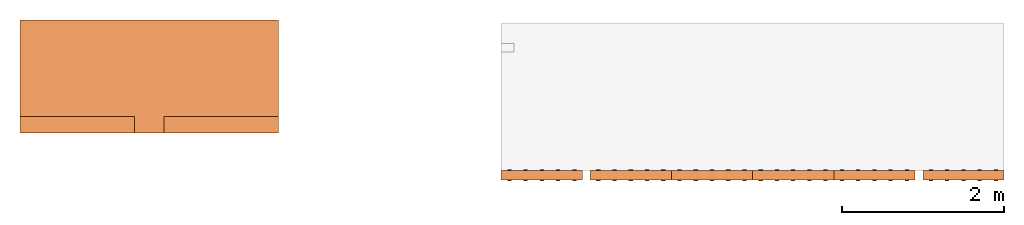
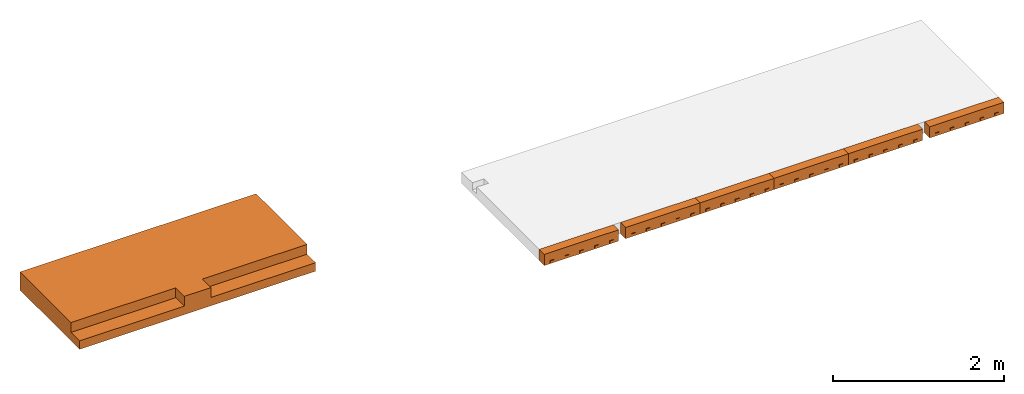
# Not in any storey, part 2 of 2: 7 proxies.
"""IFC2X3 building model written with IfcOpenShell, lengths in metres."""

from ifc_helpers import new_model, entity, si_unit, converted_unit, derived_unit, frame, origin, place, context, subcontext, project, spatial, faceted_brep, material, element, save


model = new_model("IFC2X3")

# Units and contexts
model_context = context("Model", 3, precision=1e-05, world=origin())
body_context = subcontext(model_context, "Body", "Model", "MODEL_VIEW")
ifc_project = project(units=[si_unit("LENGTHUNIT", "METRE"), si_unit("AREAUNIT", "SQUARE_METRE"), si_unit("VOLUMEUNIT", "CUBIC_METRE"), si_unit("MASSUNIT", "GRAM", prefix="KILO"), converted_unit("PLANEANGLEUNIT", "DEGREE", entity("IfcPlaneAngleMeasure", 0.0174532925199433), si_unit("PLANEANGLEUNIT", "RADIAN"), dimensions=[0, 0, 0, 0, 0, 0, 0]), derived_unit("THERMALTRANSMITTANCEUNIT", [(si_unit("POWERUNIT", "WATT"), 1), (si_unit("THERMODYNAMICTEMPERATUREUNIT", "KELVIN"), -1), (si_unit("LENGTHUNIT", "METRE"), -2)]), derived_unit("VOLUMETRICFLOWRATEUNIT", [(si_unit("LENGTHUNIT", "METRE"), 3), (converted_unit("TIMEUNIT", "hour", entity("IfcTimeMeasure", 3600.0), si_unit("TIMEUNIT", "SECOND"), dimensions=[0, 0, 1, 0, 0, 0, 0]), -1), (si_unit("LENGTHUNIT", "METRE"), -1)])], contexts=[model_context])

# Building
building_placement = place(None, origin())
building = spatial("IfcBuilding", under=ifc_project, at=building_placement, CompositionType="ELEMENT")

# Proxies
ifc_material = material()
proxy_1_placement = place(building_placement, frame((39.4091854451497, 4.88585415554066, 7.24)))
element("IfcBuildingElementProxy", 1, at=proxy_1_placement, inside=building, material=ifc_material, context=body_context, shape_type="Brep", body=[
    faceted_brep([(3.17999994515257, 1.39, 0.0), (0.0, 1.39, 0.0), (0.0, 0.0, 0.0), (3.17999994515257, 0.0, 0.0), (0.0, 1.39, 0.26), (3.17999994515257, 1.39, 0.26), (3.17999994515257, 0.200000000000004, 0.26), (1.76999994515256, 0.200000000000004, 0.26), (1.76999994515256, 0.0, 0.26), (1.41, 0.0, 0.26), (1.41, 0.200000000000004, 0.26), (0.0, 0.200000000000004, 0.26), (0.0, 0.200000000000004, 0.12), (0.0, 0.0, 0.12), (1.41, 0.0, 0.12), (1.76999994515256, 0.0, 0.12), (3.17999994515257, 0.0, 0.12), (3.17999994515256, 0.200000000000004, 0.12), (1.76999994515256, 0.200000000000004, 0.12), (1.41, 0.200000000000004, 0.12)], [[[0, 1, 2, 3]], [[4, 5, 6, 7, 8, 9, 10, 11]], [[1, 0, 5, 4]], [[2, 1, 4, 11, 12, 13]], [[3, 2, 13, 14, 9, 8, 15, 16]], [[0, 3, 16, 17, 6, 5]], [[18, 17, 16, 15]], [[7, 6, 17, 18]], [[8, 7, 18, 15]], [[12, 19, 14, 13]], [[11, 10, 19, 12]], [[10, 9, 14, 19]]], orient=[[False], [False], [False], [False], [False], [False], [False], [False], [False], [False], [False], [False]]),
])
proxy_2_placement = place(building_placement, frame((45.3333417641677, 4.29444485852216, 6.71)))
element("IfcBuildingElementProxy", 2, at=proxy_2_placement, inside=building, context=body_context, shape_type="Brep", body=[
    faceted_brep([(0.0, 0.01, 0.0), (1.0, 0.01, 0.0), (1.0, 0.13, 0.0), (0.0, 0.13, 0.0), (1.0, 0.01, 0.16), (0.0, 0.01, 0.16), (0.0, 0.13, 0.16), (1.0, 0.13, 0.16)], [[[0, 1, 2, 3]], [[4, 5, 6, 7]], [[1, 0, 5, 4]], [[2, 1, 4, 7]], [[3, 2, 7, 6]], [[0, 3, 6, 5]]], orient=[[False], [False], [False], [False], [False], [False]]),
    faceted_brep([(0.925, 0.01, 0.0475), (0.925, 0.0, 0.0475), (0.875, 0.0, 0.0475), (0.875, 0.01, 0.0475), (0.925, 0.0, 0.0175), (0.925, 0.01, 0.0175), (0.875, 0.01, 0.0175), (0.875, 0.0, 0.0175)], [[[0, 1, 2, 3]], [[4, 5, 6, 7]], [[1, 0, 5, 4]], [[2, 1, 4, 7]], [[3, 2, 7, 6]], [[0, 3, 6, 5]]], orient=[[False], [False], [False], [False], [False], [False]]),
    faceted_brep([(0.925, 0.14, 0.0475), (0.925, 0.13, 0.0475), (0.875, 0.13, 0.0475), (0.875, 0.14, 0.0475), (0.925, 0.13, 0.0175), (0.925, 0.14, 0.0175), (0.875, 0.14, 0.0175), (0.875, 0.13, 0.0175)], [[[0, 1, 2, 3]], [[4, 5, 6, 7]], [[1, 0, 5, 4]], [[2, 1, 4, 7]], [[3, 2, 7, 6]], [[0, 3, 6, 5]]], orient=[[False], [False], [False], [False], [False], [False]]),
    faceted_brep([(0.725, 0.01, 0.0475), (0.725, 0.0, 0.0475), (0.675, 0.0, 0.0475), (0.675, 0.01, 0.0475), (0.725, 0.0, 0.0175), (0.725, 0.01, 0.0175), (0.675, 0.01, 0.0175), (0.675, 0.0, 0.0175)], [[[0, 1, 2, 3]], [[4, 5, 6, 7]], [[1, 0, 5, 4]], [[2, 1, 4, 7]], [[3, 2, 7, 6]], [[0, 3, 6, 5]]], orient=[[False], [False], [False], [False], [False], [False]]),
    faceted_brep([(0.725, 0.14, 0.0475), (0.725, 0.13, 0.0475), (0.675, 0.13, 0.0475), (0.675, 0.14, 0.0475), (0.725, 0.13, 0.0175), (0.725, 0.14, 0.0175), (0.675, 0.14, 0.0175), (0.675, 0.13, 0.0175)], [[[0, 1, 2, 3]], [[4, 5, 6, 7]], [[1, 0, 5, 4]], [[2, 1, 4, 7]], [[3, 2, 7, 6]], [[0, 3, 6, 5]]], orient=[[False], [False], [False], [False], [False], [False]]),
    faceted_brep([(0.125, 0.01, 0.0475), (0.125, 0.0, 0.0475), (0.075, 0.0, 0.0475), (0.075, 0.01, 0.0475), (0.125, 0.0, 0.0175), (0.125, 0.01, 0.0175), (0.075, 0.01, 0.0175), (0.075, 0.0, 0.0175)], [[[0, 1, 2, 3]], [[4, 5, 6, 7]], [[1, 0, 5, 4]], [[2, 1, 4, 7]], [[3, 2, 7, 6]], [[0, 3, 6, 5]]], orient=[[False], [False], [False], [False], [False], [False]]),
    faceted_brep([(0.125, 0.14, 0.0475), (0.125, 0.13, 0.0475), (0.075, 0.13, 0.0475), (0.075, 0.14, 0.0475), (0.125, 0.13, 0.0175), (0.125, 0.14, 0.0175), (0.075, 0.14, 0.0175), (0.075, 0.13, 0.0175)], [[[0, 1, 2, 3]], [[4, 5, 6, 7]], [[1, 0, 5, 4]], [[2, 1, 4, 7]], [[3, 2, 7, 6]], [[0, 3, 6, 5]]], orient=[[False], [False], [False], [False], [False], [False]]),
    faceted_brep([(0.325, 0.01, 0.0475), (0.325, 0.0, 0.0475), (0.275, 0.0, 0.0475), (0.275, 0.01, 0.0475), (0.325, 0.0, 0.0175), (0.325, 0.01, 0.0175), (0.275, 0.01, 0.0175), (0.275, 0.0, 0.0175)], [[[0, 1, 2, 3]], [[4, 5, 6, 7]], [[1, 0, 5, 4]], [[2, 1, 4, 7]], [[3, 2, 7, 6]], [[0, 3, 6, 5]]], orient=[[False], [False], [False], [False], [False], [False]]),
    faceted_brep([(0.325, 0.14, 0.0475), (0.325, 0.13, 0.0475), (0.275, 0.13, 0.0475), (0.275, 0.14, 0.0475), (0.325, 0.13, 0.0175), (0.325, 0.14, 0.0175), (0.275, 0.14, 0.0175), (0.275, 0.13, 0.0175)], [[[0, 1, 2, 3]], [[4, 5, 6, 7]], [[1, 0, 5, 4]], [[2, 1, 4, 7]], [[3, 2, 7, 6]], [[0, 3, 6, 5]]], orient=[[False], [False], [False], [False], [False], [False]]),
    faceted_brep([(0.525, 0.01, 0.0475), (0.525, 0.0, 0.0475), (0.475, 0.0, 0.0475), (0.475, 0.01, 0.0475), (0.525, 0.0, 0.0175), (0.525, 0.01, 0.0175), (0.475, 0.01, 0.0175), (0.475, 0.0, 0.0175)], [[[0, 1, 2, 3]], [[4, 5, 6, 7]], [[1, 0, 5, 4]], [[2, 1, 4, 7]], [[3, 2, 7, 6]], [[0, 3, 6, 5]]], orient=[[False], [False], [False], [False], [False], [False]]),
    faceted_brep([(0.525, 0.14, 0.0475), (0.525, 0.13, 0.0475), (0.475, 0.13, 0.0475), (0.475, 0.14, 0.0475), (0.525, 0.13, 0.0175), (0.525, 0.14, 0.0175), (0.475, 0.14, 0.0175), (0.475, 0.13, 0.0175)], [[[0, 1, 2, 3]], [[4, 5, 6, 7]], [[1, 0, 5, 4]], [[2, 1, 4, 7]], [[3, 2, 7, 6]], [[0, 3, 6, 5]]], orient=[[False], [False], [False], [False], [False], [False]]),
])
proxy_3_placement = place(building_placement, frame((50.5233417641677, 4.29444485852216, 6.71)))
element("IfcBuildingElementProxy", 3, at=proxy_3_placement, inside=building, context=body_context, shape_type="Brep", body=[
    faceted_brep([(0.0, 0.01, 0.0), (1.0, 0.01, 0.0), (1.0, 0.13, 0.0), (0.0, 0.13, 0.0), (1.0, 0.01, 0.16), (0.0, 0.01, 0.16), (0.0, 0.13, 0.16), (1.0, 0.13, 0.16)], [[[0, 1, 2, 3]], [[4, 5, 6, 7]], [[1, 0, 5, 4]], [[2, 1, 4, 7]], [[3, 2, 7, 6]], [[0, 3, 6, 5]]], orient=[[False], [False], [False], [False], [False], [False]]),
    faceted_brep([(0.925, 0.01, 0.0475), (0.925, 0.0, 0.0475), (0.875, 0.0, 0.0475), (0.875, 0.01, 0.0475), (0.925, 0.0, 0.0175), (0.925, 0.01, 0.0175), (0.875, 0.01, 0.0175), (0.875, 0.0, 0.0175)], [[[0, 1, 2, 3]], [[4, 5, 6, 7]], [[1, 0, 5, 4]], [[2, 1, 4, 7]], [[3, 2, 7, 6]], [[0, 3, 6, 5]]], orient=[[False], [False], [False], [False], [False], [False]]),
    faceted_brep([(0.925, 0.14, 0.0475), (0.925, 0.13, 0.0475), (0.875, 0.13, 0.0475), (0.875, 0.14, 0.0475), (0.925, 0.13, 0.0175), (0.925, 0.14, 0.0175), (0.875, 0.14, 0.0175), (0.875, 0.13, 0.0175)], [[[0, 1, 2, 3]], [[4, 5, 6, 7]], [[1, 0, 5, 4]], [[2, 1, 4, 7]], [[3, 2, 7, 6]], [[0, 3, 6, 5]]], orient=[[False], [False], [False], [False], [False], [False]]),
    faceted_brep([(0.725, 0.01, 0.0475), (0.725, 0.0, 0.0475), (0.675, 0.0, 0.0475), (0.675, 0.01, 0.0475), (0.725, 0.0, 0.0175), (0.725, 0.01, 0.0175), (0.675, 0.01, 0.0175), (0.675, 0.0, 0.0175)], [[[0, 1, 2, 3]], [[4, 5, 6, 7]], [[1, 0, 5, 4]], [[2, 1, 4, 7]], [[3, 2, 7, 6]], [[0, 3, 6, 5]]], orient=[[False], [False], [False], [False], [False], [False]]),
    faceted_brep([(0.725, 0.14, 0.0475), (0.725, 0.13, 0.0475), (0.675, 0.13, 0.0475), (0.675, 0.14, 0.0475), (0.725, 0.13, 0.0175), (0.725, 0.14, 0.0175), (0.675, 0.14, 0.0175), (0.675, 0.13, 0.0175)], [[[0, 1, 2, 3]], [[4, 5, 6, 7]], [[1, 0, 5, 4]], [[2, 1, 4, 7]], [[3, 2, 7, 6]], [[0, 3, 6, 5]]], orient=[[False], [False], [False], [False], [False], [False]]),
    faceted_brep([(0.125, 0.01, 0.0475), (0.125, 0.0, 0.0475), (0.075, 0.0, 0.0475), (0.075, 0.01, 0.0475), (0.125, 0.0, 0.0175), (0.125, 0.01, 0.0175), (0.075, 0.01, 0.0175), (0.075, 0.0, 0.0175)], [[[0, 1, 2, 3]], [[4, 5, 6, 7]], [[1, 0, 5, 4]], [[2, 1, 4, 7]], [[3, 2, 7, 6]], [[0, 3, 6, 5]]], orient=[[False], [False], [False], [False], [False], [False]]),
    faceted_brep([(0.125, 0.14, 0.0475), (0.125, 0.13, 0.0475), (0.075, 0.13, 0.0475), (0.075, 0.14, 0.0475), (0.125, 0.13, 0.0175), (0.125, 0.14, 0.0175), (0.075, 0.14, 0.0175), (0.075, 0.13, 0.0175)], [[[0, 1, 2, 3]], [[4, 5, 6, 7]], [[1, 0, 5, 4]], [[2, 1, 4, 7]], [[3, 2, 7, 6]], [[0, 3, 6, 5]]], orient=[[False], [False], [False], [False], [False], [False]]),
    faceted_brep([(0.325, 0.01, 0.0475), (0.325, 0.0, 0.0475), (0.275, 0.0, 0.0475), (0.275, 0.01, 0.0475), (0.325, 0.0, 0.0175), (0.325, 0.01, 0.0175), (0.275, 0.01, 0.0175), (0.275, 0.0, 0.0175)], [[[0, 1, 2, 3]], [[4, 5, 6, 7]], [[1, 0, 5, 4]], [[2, 1, 4, 7]], [[3, 2, 7, 6]], [[0, 3, 6, 5]]], orient=[[False], [False], [False], [False], [False], [False]]),
    faceted_brep([(0.325, 0.14, 0.0475), (0.325, 0.13, 0.0475), (0.275, 0.13, 0.0475), (0.275, 0.14, 0.0475), (0.325, 0.13, 0.0175), (0.325, 0.14, 0.0175), (0.275, 0.14, 0.0175), (0.275, 0.13, 0.0175)], [[[0, 1, 2, 3]], [[4, 5, 6, 7]], [[1, 0, 5, 4]], [[2, 1, 4, 7]], [[3, 2, 7, 6]], [[0, 3, 6, 5]]], orient=[[False], [False], [False], [False], [False], [False]]),
    faceted_brep([(0.525, 0.01, 0.0475), (0.525, 0.0, 0.0475), (0.475, 0.0, 0.0475), (0.475, 0.01, 0.0475), (0.525, 0.0, 0.0175), (0.525, 0.01, 0.0175), (0.475, 0.01, 0.0175), (0.475, 0.0, 0.0175)], [[[0, 1, 2, 3]], [[4, 5, 6, 7]], [[1, 0, 5, 4]], [[2, 1, 4, 7]], [[3, 2, 7, 6]], [[0, 3, 6, 5]]], orient=[[False], [False], [False], [False], [False], [False]]),
    faceted_brep([(0.525, 0.14, 0.0475), (0.525, 0.13, 0.0475), (0.475, 0.13, 0.0475), (0.475, 0.14, 0.0475), (0.525, 0.13, 0.0175), (0.525, 0.14, 0.0175), (0.475, 0.14, 0.0175), (0.475, 0.13, 0.0175)], [[[0, 1, 2, 3]], [[4, 5, 6, 7]], [[1, 0, 5, 4]], [[2, 1, 4, 7]], [[3, 2, 7, 6]], [[0, 3, 6, 5]]], orient=[[False], [False], [False], [False], [False], [False]]),
])
proxy_4_placement = place(building_placement, frame((49.4283417641678, 4.29444487685715, 6.71)))
element("IfcBuildingElementProxy", 4, at=proxy_4_placement, inside=building, context=body_context, shape_type="Brep", body=[
    faceted_brep([(0.0, 0.01, 0.0), (1.0, 0.01, 0.0), (1.0, 0.13, 0.0), (0.0, 0.13, 0.0), (1.0, 0.01, 0.16), (0.0, 0.01, 0.16), (0.0, 0.13, 0.16), (1.0, 0.13, 0.16)], [[[0, 1, 2, 3]], [[4, 5, 6, 7]], [[1, 0, 5, 4]], [[2, 1, 4, 7]], [[3, 2, 7, 6]], [[0, 3, 6, 5]]], orient=[[False], [False], [False], [False], [False], [False]]),
    faceted_brep([(0.925, 0.01, 0.0475), (0.925, 0.0, 0.0475), (0.875, 0.0, 0.0475), (0.875, 0.01, 0.0475), (0.925, 0.0, 0.0175), (0.925, 0.01, 0.0175), (0.875, 0.01, 0.0175), (0.875, 0.0, 0.0175)], [[[0, 1, 2, 3]], [[4, 5, 6, 7]], [[1, 0, 5, 4]], [[2, 1, 4, 7]], [[3, 2, 7, 6]], [[0, 3, 6, 5]]], orient=[[False], [False], [False], [False], [False], [False]]),
    faceted_brep([(0.925, 0.14, 0.0475), (0.925, 0.13, 0.0475), (0.875, 0.13, 0.0475), (0.875, 0.14, 0.0475), (0.925, 0.13, 0.0175), (0.925, 0.14, 0.0175), (0.875, 0.14, 0.0175), (0.875, 0.13, 0.0175)], [[[0, 1, 2, 3]], [[4, 5, 6, 7]], [[1, 0, 5, 4]], [[2, 1, 4, 7]], [[3, 2, 7, 6]], [[0, 3, 6, 5]]], orient=[[False], [False], [False], [False], [False], [False]]),
    faceted_brep([(0.725, 0.01, 0.0475), (0.725, 0.0, 0.0475), (0.675, 0.0, 0.0475), (0.675, 0.01, 0.0475), (0.725, 0.0, 0.0175), (0.725, 0.01, 0.0175), (0.675, 0.01, 0.0175), (0.675, 0.0, 0.0175)], [[[0, 1, 2, 3]], [[4, 5, 6, 7]], [[1, 0, 5, 4]], [[2, 1, 4, 7]], [[3, 2, 7, 6]], [[0, 3, 6, 5]]], orient=[[False], [False], [False], [False], [False], [False]]),
    faceted_brep([(0.725, 0.14, 0.0475), (0.725, 0.13, 0.0475), (0.675, 0.13, 0.0475), (0.675, 0.14, 0.0475), (0.725, 0.13, 0.0175), (0.725, 0.14, 0.0175), (0.675, 0.14, 0.0175), (0.675, 0.13, 0.0175)], [[[0, 1, 2, 3]], [[4, 5, 6, 7]], [[1, 0, 5, 4]], [[2, 1, 4, 7]], [[3, 2, 7, 6]], [[0, 3, 6, 5]]], orient=[[False], [False], [False], [False], [False], [False]]),
    faceted_brep([(0.125, 0.01, 0.0475), (0.125, 0.0, 0.0475), (0.075, 0.0, 0.0475), (0.075, 0.01, 0.0475), (0.125, 0.0, 0.0175), (0.125, 0.01, 0.0175), (0.075, 0.01, 0.0175), (0.075, 0.0, 0.0175)], [[[0, 1, 2, 3]], [[4, 5, 6, 7]], [[1, 0, 5, 4]], [[2, 1, 4, 7]], [[3, 2, 7, 6]], [[0, 3, 6, 5]]], orient=[[False], [False], [False], [False], [False], [False]]),
    faceted_brep([(0.125, 0.14, 0.0475), (0.125, 0.13, 0.0475), (0.075, 0.13, 0.0475), (0.075, 0.14, 0.0475), (0.125, 0.13, 0.0175), (0.125, 0.14, 0.0175), (0.075, 0.14, 0.0175), (0.075, 0.13, 0.0175)], [[[0, 1, 2, 3]], [[4, 5, 6, 7]], [[1, 0, 5, 4]], [[2, 1, 4, 7]], [[3, 2, 7, 6]], [[0, 3, 6, 5]]], orient=[[False], [False], [False], [False], [False], [False]]),
    faceted_brep([(0.325, 0.01, 0.0475), (0.325, 0.0, 0.0475), (0.275, 0.0, 0.0475), (0.275, 0.01, 0.0475), (0.325, 0.0, 0.0175), (0.325, 0.01, 0.0175), (0.275, 0.01, 0.0175), (0.275, 0.0, 0.0175)], [[[0, 1, 2, 3]], [[4, 5, 6, 7]], [[1, 0, 5, 4]], [[2, 1, 4, 7]], [[3, 2, 7, 6]], [[0, 3, 6, 5]]], orient=[[False], [False], [False], [False], [False], [False]]),
    faceted_brep([(0.325, 0.14, 0.0475), (0.325, 0.13, 0.0475), (0.275, 0.13, 0.0475), (0.275, 0.14, 0.0475), (0.325, 0.13, 0.0175), (0.325, 0.14, 0.0175), (0.275, 0.14, 0.0175), (0.275, 0.13, 0.0175)], [[[0, 1, 2, 3]], [[4, 5, 6, 7]], [[1, 0, 5, 4]], [[2, 1, 4, 7]], [[3, 2, 7, 6]], [[0, 3, 6, 5]]], orient=[[False], [False], [False], [False], [False], [False]]),
    faceted_brep([(0.525, 0.01, 0.0475), (0.525, 0.0, 0.0475), (0.475, 0.0, 0.0475), (0.475, 0.01, 0.0475), (0.525, 0.0, 0.0175), (0.525, 0.01, 0.0175), (0.475, 0.01, 0.0175), (0.475, 0.0, 0.0175)], [[[0, 1, 2, 3]], [[4, 5, 6, 7]], [[1, 0, 5, 4]], [[2, 1, 4, 7]], [[3, 2, 7, 6]], [[0, 3, 6, 5]]], orient=[[False], [False], [False], [False], [False], [False]]),
    faceted_brep([(0.525, 0.14, 0.0475), (0.525, 0.13, 0.0475), (0.475, 0.13, 0.0475), (0.475, 0.14, 0.0475), (0.525, 0.13, 0.0175), (0.525, 0.14, 0.0175), (0.475, 0.14, 0.0175), (0.475, 0.13, 0.0175)], [[[0, 1, 2, 3]], [[4, 5, 6, 7]], [[1, 0, 5, 4]], [[2, 1, 4, 7]], [[3, 2, 7, 6]], [[0, 3, 6, 5]]], orient=[[False], [False], [False], [False], [False], [False]]),
])
proxy_5_placement = place(building_placement, frame((46.4283417641678, 4.29444487685715, 6.71)))
element("IfcBuildingElementProxy", 5, at=proxy_5_placement, inside=building, context=body_context, shape_type="Brep", body=[
    faceted_brep([(0.0, 0.01, 0.0), (1.0, 0.01, 0.0), (1.0, 0.13, 0.0), (0.0, 0.13, 0.0), (1.0, 0.01, 0.16), (0.0, 0.01, 0.16), (0.0, 0.13, 0.16), (1.0, 0.13, 0.16)], [[[0, 1, 2, 3]], [[4, 5, 6, 7]], [[1, 0, 5, 4]], [[2, 1, 4, 7]], [[3, 2, 7, 6]], [[0, 3, 6, 5]]], orient=[[False], [False], [False], [False], [False], [False]]),
    faceted_brep([(0.925, 0.01, 0.0475), (0.925, 0.0, 0.0475), (0.875, 0.0, 0.0475), (0.875, 0.01, 0.0475), (0.925, 0.0, 0.0175), (0.925, 0.01, 0.0175), (0.875, 0.01, 0.0175), (0.875, 0.0, 0.0175)], [[[0, 1, 2, 3]], [[4, 5, 6, 7]], [[1, 0, 5, 4]], [[2, 1, 4, 7]], [[3, 2, 7, 6]], [[0, 3, 6, 5]]], orient=[[False], [False], [False], [False], [False], [False]]),
    faceted_brep([(0.925, 0.14, 0.0475), (0.925, 0.13, 0.0475), (0.875, 0.13, 0.0475), (0.875, 0.14, 0.0475), (0.925, 0.13, 0.0175), (0.925, 0.14, 0.0175), (0.875, 0.14, 0.0175), (0.875, 0.13, 0.0175)], [[[0, 1, 2, 3]], [[4, 5, 6, 7]], [[1, 0, 5, 4]], [[2, 1, 4, 7]], [[3, 2, 7, 6]], [[0, 3, 6, 5]]], orient=[[False], [False], [False], [False], [False], [False]]),
    faceted_brep([(0.725, 0.01, 0.0475), (0.725, 0.0, 0.0475), (0.675, 0.0, 0.0475), (0.675, 0.01, 0.0475), (0.725, 0.0, 0.0175), (0.725, 0.01, 0.0175), (0.675, 0.01, 0.0175), (0.675, 0.0, 0.0175)], [[[0, 1, 2, 3]], [[4, 5, 6, 7]], [[1, 0, 5, 4]], [[2, 1, 4, 7]], [[3, 2, 7, 6]], [[0, 3, 6, 5]]], orient=[[False], [False], [False], [False], [False], [False]]),
    faceted_brep([(0.725, 0.14, 0.0475), (0.725, 0.13, 0.0475), (0.675, 0.13, 0.0475), (0.675, 0.14, 0.0475), (0.725, 0.13, 0.0175), (0.725, 0.14, 0.0175), (0.675, 0.14, 0.0175), (0.675, 0.13, 0.0175)], [[[0, 1, 2, 3]], [[4, 5, 6, 7]], [[1, 0, 5, 4]], [[2, 1, 4, 7]], [[3, 2, 7, 6]], [[0, 3, 6, 5]]], orient=[[False], [False], [False], [False], [False], [False]]),
    faceted_brep([(0.125, 0.01, 0.0475), (0.125, 0.0, 0.0475), (0.075, 0.0, 0.0475), (0.075, 0.01, 0.0475), (0.125, 0.0, 0.0175), (0.125, 0.01, 0.0175), (0.075, 0.01, 0.0175), (0.075, 0.0, 0.0175)], [[[0, 1, 2, 3]], [[4, 5, 6, 7]], [[1, 0, 5, 4]], [[2, 1, 4, 7]], [[3, 2, 7, 6]], [[0, 3, 6, 5]]], orient=[[False], [False], [False], [False], [False], [False]]),
    faceted_brep([(0.125, 0.14, 0.0475), (0.125, 0.13, 0.0475), (0.075, 0.13, 0.0475), (0.075, 0.14, 0.0475), (0.125, 0.13, 0.0175), (0.125, 0.14, 0.0175), (0.075, 0.14, 0.0175), (0.075, 0.13, 0.0175)], [[[0, 1, 2, 3]], [[4, 5, 6, 7]], [[1, 0, 5, 4]], [[2, 1, 4, 7]], [[3, 2, 7, 6]], [[0, 3, 6, 5]]], orient=[[False], [False], [False], [False], [False], [False]]),
    faceted_brep([(0.325, 0.01, 0.0475), (0.325, 0.0, 0.0475), (0.275, 0.0, 0.0475), (0.275, 0.01, 0.0475), (0.325, 0.0, 0.0175), (0.325, 0.01, 0.0175), (0.275, 0.01, 0.0175), (0.275, 0.0, 0.0175)], [[[0, 1, 2, 3]], [[4, 5, 6, 7]], [[1, 0, 5, 4]], [[2, 1, 4, 7]], [[3, 2, 7, 6]], [[0, 3, 6, 5]]], orient=[[False], [False], [False], [False], [False], [False]]),
    faceted_brep([(0.325, 0.14, 0.0475), (0.325, 0.13, 0.0475), (0.275, 0.13, 0.0475), (0.275, 0.14, 0.0475), (0.325, 0.13, 0.0175), (0.325, 0.14, 0.0175), (0.275, 0.14, 0.0175), (0.275, 0.13, 0.0175)], [[[0, 1, 2, 3]], [[4, 5, 6, 7]], [[1, 0, 5, 4]], [[2, 1, 4, 7]], [[3, 2, 7, 6]], [[0, 3, 6, 5]]], orient=[[False], [False], [False], [False], [False], [False]]),
    faceted_brep([(0.525, 0.01, 0.0475), (0.525, 0.0, 0.0475), (0.475, 0.0, 0.0475), (0.475, 0.01, 0.0475), (0.525, 0.0, 0.0175), (0.525, 0.01, 0.0175), (0.475, 0.01, 0.0175), (0.475, 0.0, 0.0175)], [[[0, 1, 2, 3]], [[4, 5, 6, 7]], [[1, 0, 5, 4]], [[2, 1, 4, 7]], [[3, 2, 7, 6]], [[0, 3, 6, 5]]], orient=[[False], [False], [False], [False], [False], [False]]),
    faceted_brep([(0.525, 0.14, 0.0475), (0.525, 0.13, 0.0475), (0.475, 0.13, 0.0475), (0.475, 0.14, 0.0475), (0.525, 0.13, 0.0175), (0.525, 0.14, 0.0175), (0.475, 0.14, 0.0175), (0.475, 0.13, 0.0175)], [[[0, 1, 2, 3]], [[4, 5, 6, 7]], [[1, 0, 5, 4]], [[2, 1, 4, 7]], [[3, 2, 7, 6]], [[0, 3, 6, 5]]], orient=[[False], [False], [False], [False], [False], [False]]),
])
proxy_6_placement = place(building_placement, frame((47.4283417641678, 4.29444487685715, 6.71)))
element("IfcBuildingElementProxy", 6, at=proxy_6_placement, inside=building, context=body_context, shape_type="Brep", body=[
    faceted_brep([(0.0, 0.01, 0.0), (1.0, 0.01, 0.0), (1.0, 0.13, 0.0), (0.0, 0.13, 0.0), (1.0, 0.01, 0.16), (0.0, 0.01, 0.16), (0.0, 0.13, 0.16), (1.0, 0.13, 0.16)], [[[0, 1, 2, 3]], [[4, 5, 6, 7]], [[1, 0, 5, 4]], [[2, 1, 4, 7]], [[3, 2, 7, 6]], [[0, 3, 6, 5]]], orient=[[False], [False], [False], [False], [False], [False]]),
    faceted_brep([(0.925, 0.01, 0.0475), (0.925, 0.0, 0.0475), (0.875, 0.0, 0.0475), (0.875, 0.01, 0.0475), (0.925, 0.0, 0.0175), (0.925, 0.01, 0.0175), (0.875, 0.01, 0.0175), (0.875, 0.0, 0.0175)], [[[0, 1, 2, 3]], [[4, 5, 6, 7]], [[1, 0, 5, 4]], [[2, 1, 4, 7]], [[3, 2, 7, 6]], [[0, 3, 6, 5]]], orient=[[False], [False], [False], [False], [False], [False]]),
    faceted_brep([(0.925, 0.14, 0.0475), (0.925, 0.13, 0.0475), (0.875, 0.13, 0.0475), (0.875, 0.14, 0.0475), (0.925, 0.13, 0.0175), (0.925, 0.14, 0.0175), (0.875, 0.14, 0.0175), (0.875, 0.13, 0.0175)], [[[0, 1, 2, 3]], [[4, 5, 6, 7]], [[1, 0, 5, 4]], [[2, 1, 4, 7]], [[3, 2, 7, 6]], [[0, 3, 6, 5]]], orient=[[False], [False], [False], [False], [False], [False]]),
    faceted_brep([(0.725, 0.01, 0.0475), (0.725, 0.0, 0.0475), (0.675, 0.0, 0.0475), (0.675, 0.01, 0.0475), (0.725, 0.0, 0.0175), (0.725, 0.01, 0.0175), (0.675, 0.01, 0.0175), (0.675, 0.0, 0.0175)], [[[0, 1, 2, 3]], [[4, 5, 6, 7]], [[1, 0, 5, 4]], [[2, 1, 4, 7]], [[3, 2, 7, 6]], [[0, 3, 6, 5]]], orient=[[False], [False], [False], [False], [False], [False]]),
    faceted_brep([(0.725, 0.14, 0.0475), (0.725, 0.13, 0.0475), (0.675, 0.13, 0.0475), (0.675, 0.14, 0.0475), (0.725, 0.13, 0.0175), (0.725, 0.14, 0.0175), (0.675, 0.14, 0.0175), (0.675, 0.13, 0.0175)], [[[0, 1, 2, 3]], [[4, 5, 6, 7]], [[1, 0, 5, 4]], [[2, 1, 4, 7]], [[3, 2, 7, 6]], [[0, 3, 6, 5]]], orient=[[False], [False], [False], [False], [False], [False]]),
    faceted_brep([(0.125, 0.01, 0.0475), (0.125, 0.0, 0.0475), (0.075, 0.0, 0.0475), (0.075, 0.01, 0.0475), (0.125, 0.0, 0.0175), (0.125, 0.01, 0.0175), (0.075, 0.01, 0.0175), (0.075, 0.0, 0.0175)], [[[0, 1, 2, 3]], [[4, 5, 6, 7]], [[1, 0, 5, 4]], [[2, 1, 4, 7]], [[3, 2, 7, 6]], [[0, 3, 6, 5]]], orient=[[False], [False], [False], [False], [False], [False]]),
    faceted_brep([(0.125, 0.14, 0.0475), (0.125, 0.13, 0.0475), (0.075, 0.13, 0.0475), (0.075, 0.14, 0.0475), (0.125, 0.13, 0.0175), (0.125, 0.14, 0.0175), (0.075, 0.14, 0.0175), (0.075, 0.13, 0.0175)], [[[0, 1, 2, 3]], [[4, 5, 6, 7]], [[1, 0, 5, 4]], [[2, 1, 4, 7]], [[3, 2, 7, 6]], [[0, 3, 6, 5]]], orient=[[False], [False], [False], [False], [False], [False]]),
    faceted_brep([(0.325, 0.01, 0.0475), (0.325, 0.0, 0.0475), (0.275, 0.0, 0.0475), (0.275, 0.01, 0.0475), (0.325, 0.0, 0.0175), (0.325, 0.01, 0.0175), (0.275, 0.01, 0.0175), (0.275, 0.0, 0.0175)], [[[0, 1, 2, 3]], [[4, 5, 6, 7]], [[1, 0, 5, 4]], [[2, 1, 4, 7]], [[3, 2, 7, 6]], [[0, 3, 6, 5]]], orient=[[False], [False], [False], [False], [False], [False]]),
    faceted_brep([(0.325, 0.14, 0.0475), (0.325, 0.13, 0.0475), (0.275, 0.13, 0.0475), (0.275, 0.14, 0.0475), (0.325, 0.13, 0.0175), (0.325, 0.14, 0.0175), (0.275, 0.14, 0.0175), (0.275, 0.13, 0.0175)], [[[0, 1, 2, 3]], [[4, 5, 6, 7]], [[1, 0, 5, 4]], [[2, 1, 4, 7]], [[3, 2, 7, 6]], [[0, 3, 6, 5]]], orient=[[False], [False], [False], [False], [False], [False]]),
    faceted_brep([(0.525, 0.01, 0.0475), (0.525, 0.0, 0.0475), (0.475, 0.0, 0.0475), (0.475, 0.01, 0.0475), (0.525, 0.0, 0.0175), (0.525, 0.01, 0.0175), (0.475, 0.01, 0.0175), (0.475, 0.0, 0.0175)], [[[0, 1, 2, 3]], [[4, 5, 6, 7]], [[1, 0, 5, 4]], [[2, 1, 4, 7]], [[3, 2, 7, 6]], [[0, 3, 6, 5]]], orient=[[False], [False], [False], [False], [False], [False]]),
    faceted_brep([(0.525, 0.14, 0.0475), (0.525, 0.13, 0.0475), (0.475, 0.13, 0.0475), (0.475, 0.14, 0.0475), (0.525, 0.13, 0.0175), (0.525, 0.14, 0.0175), (0.475, 0.14, 0.0175), (0.475, 0.13, 0.0175)], [[[0, 1, 2, 3]], [[4, 5, 6, 7]], [[1, 0, 5, 4]], [[2, 1, 4, 7]], [[3, 2, 7, 6]], [[0, 3, 6, 5]]], orient=[[False], [False], [False], [False], [False], [False]]),
])
proxy_7_placement = place(building_placement, frame((48.4283417641678, 4.29444487685715, 6.71)))
element("IfcBuildingElementProxy", 7, at=proxy_7_placement, inside=building, context=body_context, shape_type="Brep", body=[
    faceted_brep([(0.0, 0.01, 0.0), (1.0, 0.01, 0.0), (1.0, 0.13, 0.0), (0.0, 0.13, 0.0), (1.0, 0.01, 0.16), (0.0, 0.01, 0.16), (0.0, 0.13, 0.16), (1.0, 0.13, 0.16)], [[[0, 1, 2, 3]], [[4, 5, 6, 7]], [[1, 0, 5, 4]], [[2, 1, 4, 7]], [[3, 2, 7, 6]], [[0, 3, 6, 5]]], orient=[[False], [False], [False], [False], [False], [False]]),
    faceted_brep([(0.925, 0.01, 0.0475), (0.925, 0.0, 0.0475), (0.875, 0.0, 0.0475), (0.875, 0.01, 0.0475), (0.925, 0.0, 0.0175), (0.925, 0.01, 0.0175), (0.875, 0.01, 0.0175), (0.875, 0.0, 0.0175)], [[[0, 1, 2, 3]], [[4, 5, 6, 7]], [[1, 0, 5, 4]], [[2, 1, 4, 7]], [[3, 2, 7, 6]], [[0, 3, 6, 5]]], orient=[[False], [False], [False], [False], [False], [False]]),
    faceted_brep([(0.925, 0.14, 0.0475), (0.925, 0.13, 0.0475), (0.875, 0.13, 0.0475), (0.875, 0.14, 0.0475), (0.925, 0.13, 0.0175), (0.925, 0.14, 0.0175), (0.875, 0.14, 0.0175), (0.875, 0.13, 0.0175)], [[[0, 1, 2, 3]], [[4, 5, 6, 7]], [[1, 0, 5, 4]], [[2, 1, 4, 7]], [[3, 2, 7, 6]], [[0, 3, 6, 5]]], orient=[[False], [False], [False], [False], [False], [False]]),
    faceted_brep([(0.725, 0.01, 0.0475), (0.725, 0.0, 0.0475), (0.675, 0.0, 0.0475), (0.675, 0.01, 0.0475), (0.725, 0.0, 0.0175), (0.725, 0.01, 0.0175), (0.675, 0.01, 0.0175), (0.675, 0.0, 0.0175)], [[[0, 1, 2, 3]], [[4, 5, 6, 7]], [[1, 0, 5, 4]], [[2, 1, 4, 7]], [[3, 2, 7, 6]], [[0, 3, 6, 5]]], orient=[[False], [False], [False], [False], [False], [False]]),
    faceted_brep([(0.725, 0.14, 0.0475), (0.725, 0.13, 0.0475), (0.675, 0.13, 0.0475), (0.675, 0.14, 0.0475), (0.725, 0.13, 0.0175), (0.725, 0.14, 0.0175), (0.675, 0.14, 0.0175), (0.675, 0.13, 0.0175)], [[[0, 1, 2, 3]], [[4, 5, 6, 7]], [[1, 0, 5, 4]], [[2, 1, 4, 7]], [[3, 2, 7, 6]], [[0, 3, 6, 5]]], orient=[[False], [False], [False], [False], [False], [False]]),
    faceted_brep([(0.125, 0.01, 0.0475), (0.125, 0.0, 0.0475), (0.075, 0.0, 0.0475), (0.075, 0.01, 0.0475), (0.125, 0.0, 0.0175), (0.125, 0.01, 0.0175), (0.075, 0.01, 0.0175), (0.075, 0.0, 0.0175)], [[[0, 1, 2, 3]], [[4, 5, 6, 7]], [[1, 0, 5, 4]], [[2, 1, 4, 7]], [[3, 2, 7, 6]], [[0, 3, 6, 5]]], orient=[[False], [False], [False], [False], [False], [False]]),
    faceted_brep([(0.125, 0.14, 0.0475), (0.125, 0.13, 0.0475), (0.075, 0.13, 0.0475), (0.075, 0.14, 0.0475), (0.125, 0.13, 0.0175), (0.125, 0.14, 0.0175), (0.075, 0.14, 0.0175), (0.075, 0.13, 0.0175)], [[[0, 1, 2, 3]], [[4, 5, 6, 7]], [[1, 0, 5, 4]], [[2, 1, 4, 7]], [[3, 2, 7, 6]], [[0, 3, 6, 5]]], orient=[[False], [False], [False], [False], [False], [False]]),
    faceted_brep([(0.325, 0.01, 0.0475), (0.325, 0.0, 0.0475), (0.275, 0.0, 0.0475), (0.275, 0.01, 0.0475), (0.325, 0.0, 0.0175), (0.325, 0.01, 0.0175), (0.275, 0.01, 0.0175), (0.275, 0.0, 0.0175)], [[[0, 1, 2, 3]], [[4, 5, 6, 7]], [[1, 0, 5, 4]], [[2, 1, 4, 7]], [[3, 2, 7, 6]], [[0, 3, 6, 5]]], orient=[[False], [False], [False], [False], [False], [False]]),
    faceted_brep([(0.325, 0.14, 0.0475), (0.325, 0.13, 0.0475), (0.275, 0.13, 0.0475), (0.275, 0.14, 0.0475), (0.325, 0.13, 0.0175), (0.325, 0.14, 0.0175), (0.275, 0.14, 0.0175), (0.275, 0.13, 0.0175)], [[[0, 1, 2, 3]], [[4, 5, 6, 7]], [[1, 0, 5, 4]], [[2, 1, 4, 7]], [[3, 2, 7, 6]], [[0, 3, 6, 5]]], orient=[[False], [False], [False], [False], [False], [False]]),
    faceted_brep([(0.525, 0.01, 0.0475), (0.525, 0.0, 0.0475), (0.475, 0.0, 0.0475), (0.475, 0.01, 0.0475), (0.525, 0.0, 0.0175), (0.525, 0.01, 0.0175), (0.475, 0.01, 0.0175), (0.475, 0.0, 0.0175)], [[[0, 1, 2, 3]], [[4, 5, 6, 7]], [[1, 0, 5, 4]], [[2, 1, 4, 7]], [[3, 2, 7, 6]], [[0, 3, 6, 5]]], orient=[[False], [False], [False], [False], [False], [False]]),
    faceted_brep([(0.525, 0.14, 0.0475), (0.525, 0.13, 0.0475), (0.475, 0.13, 0.0475), (0.475, 0.14, 0.0475), (0.525, 0.13, 0.0175), (0.525, 0.14, 0.0175), (0.475, 0.14, 0.0175), (0.475, 0.13, 0.0175)], [[[0, 1, 2, 3]], [[4, 5, 6, 7]], [[1, 0, 5, 4]], [[2, 1, 4, 7]], [[3, 2, 7, 6]], [[0, 3, 6, 5]]], orient=[[False], [False], [False], [False], [False], [False]]),
])

save(model, "model.ifc")
